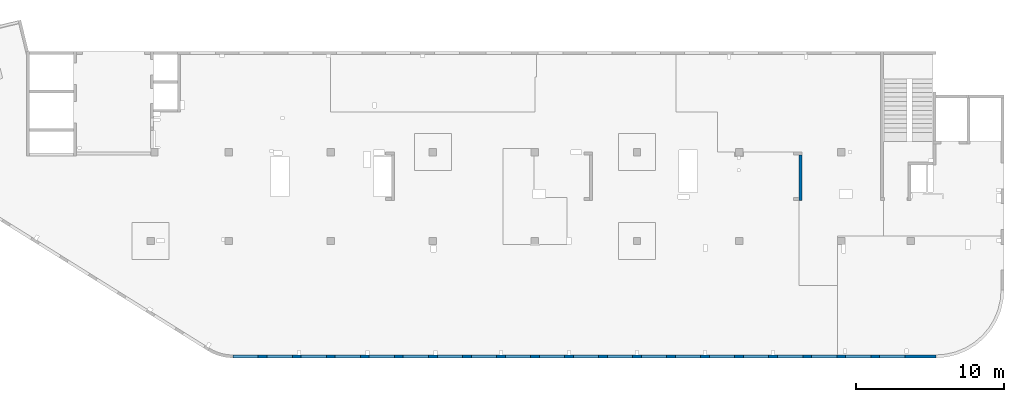
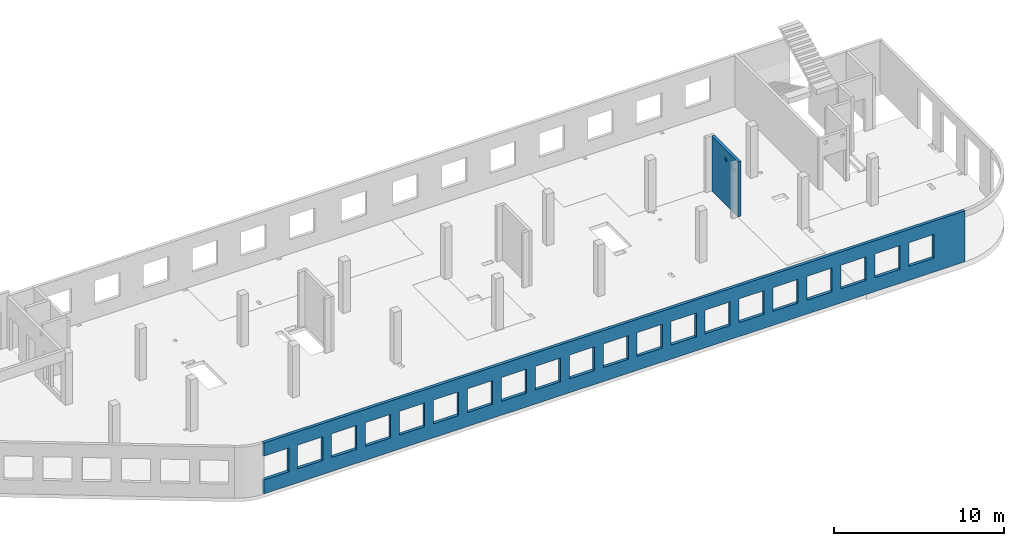
# One storey, part 5 of 6: 2 walls, 22 openings.
"""IFC4 building model written with IfcOpenShell, lengths in millimetres."""

from ifc_helpers import new_model, entity, si_unit, converted_unit, derived_unit, direction, frame, origin, place, context, subcontext, project, spatial, indexed_curve, outline, extrude, polygons, material, type_object, element, save


model = new_model("IFC4")

# Units and contexts
model_context = context("Model", 3, precision=0.01, world=origin(), true_north=direction((6.12303176911189e-17, 1.0)))
plan_context = context("Plan", 3, precision=0.01, world=origin(), true_north=direction((6.12303176911189e-17, 1.0)))
body_context = subcontext(model_context, "Body", "Model", "MODEL_VIEW")
ifc_project = project(units=[si_unit("LENGTHUNIT", "METRE", prefix="MILLI"), si_unit("AREAUNIT", "SQUARE_METRE"), si_unit("VOLUMEUNIT", "CUBIC_METRE"), converted_unit("PLANEANGLEUNIT", "DEGREE", entity("IfcRatioMeasure", 0.0174532925199433), si_unit("PLANEANGLEUNIT", "RADIAN"), dimensions=[0, 0, 0, 0, 0, 0, 0]), si_unit("MASSUNIT", "GRAM", prefix="KILO"), derived_unit("MASSDENSITYUNIT", [(si_unit("MASSUNIT", "GRAM", prefix="KILO"), 1), (si_unit("LENGTHUNIT", "METRE"), -3)]), derived_unit("MOMENTOFINERTIAUNIT", [(si_unit("LENGTHUNIT", "METRE"), 4)]), si_unit("TIMEUNIT", "SECOND"), si_unit("FREQUENCYUNIT", "HERTZ"), si_unit("THERMODYNAMICTEMPERATUREUNIT", "DEGREE_CELSIUS"), derived_unit("THERMALTRANSMITTANCEUNIT", [(si_unit("MASSUNIT", "GRAM", prefix="KILO"), 1), (si_unit("THERMODYNAMICTEMPERATUREUNIT", "KELVIN"), -1), (si_unit("TIMEUNIT", "SECOND"), -3)]), derived_unit("VOLUMETRICFLOWRATEUNIT", [(si_unit("LENGTHUNIT", "METRE"), 3), (si_unit("TIMEUNIT", "SECOND"), -1)]), derived_unit("MASSFLOWRATEUNIT", [(si_unit("MASSUNIT", "GRAM", prefix="KILO"), 1), (si_unit("TIMEUNIT", "SECOND"), -1)]), derived_unit("ROTATIONALFREQUENCYUNIT", [(si_unit("TIMEUNIT", "SECOND"), -1)]), si_unit("ELECTRICCURRENTUNIT", "AMPERE"), si_unit("ELECTRICVOLTAGEUNIT", "VOLT"), si_unit("POWERUNIT", "WATT"), si_unit("FORCEUNIT", "NEWTON", prefix="KILO"), si_unit("ILLUMINANCEUNIT", "LUX"), si_unit("LUMINOUSFLUXUNIT", "LUMEN"), si_unit("LUMINOUSINTENSITYUNIT", "CANDELA"), derived_unit("USERDEFINED", [(si_unit("MASSUNIT", "GRAM", prefix="KILO"), -1), (si_unit("LENGTHUNIT", "METRE"), -2), (si_unit("TIMEUNIT", "SECOND"), 3), (si_unit("LUMINOUSFLUXUNIT", "LUMEN"), 1)]), derived_unit("LINEARVELOCITYUNIT", [(si_unit("LENGTHUNIT", "METRE"), 1), (si_unit("TIMEUNIT", "SECOND"), -1)]), si_unit("PRESSUREUNIT", "PASCAL"), derived_unit("USERDEFINED", [(si_unit("LENGTHUNIT", "METRE"), -2), (si_unit("MASSUNIT", "GRAM", prefix="KILO"), 1), (si_unit("TIMEUNIT", "SECOND"), -2)]), derived_unit("LINEARFORCEUNIT", [(si_unit("MASSUNIT", "GRAM", prefix="KILO"), 1), (si_unit("LENGTHUNIT", "METRE"), 1), (si_unit("TIMEUNIT", "SECOND"), -2), (si_unit("LENGTHUNIT", "METRE"), -1)]), derived_unit("PLANARFORCEUNIT", [(si_unit("MASSUNIT", "GRAM", prefix="KILO"), 1), (si_unit("LENGTHUNIT", "METRE"), 1), (si_unit("TIMEUNIT", "SECOND"), -2), (si_unit("LENGTHUNIT", "METRE"), -2)])], contexts=[model_context, plan_context])

# Site, building, storey
site_placement = place(None, origin())
site = spatial("IfcSite", under=ifc_project, at=site_placement, CompositionType="ELEMENT")
building_placement = place(site_placement, origin())
building = spatial("IfcBuilding", under=site, at=building_placement, CompositionType="ELEMENT")
storey_placement = place(building_placement, frame((0.0, 0.0, 8100.0)))
storey = spatial("IfcBuildingStorey", under=building, at=storey_placement, CompositionType="ELEMENT", Elevation=8100.0)

# Wall, openings
ifc_material = material()
wall_type = type_object("IfcWallType", PredefinedType="STANDARD")
wall_1_placement = place(storey_placement, frame((68970.0002685547, -99.9999557734324, -150.0), z_axis=(0.0, 0.0, 1.0), x_axis=(-1.0, 0.0, 0.0)))
wall_1 = element("IfcWall", 1, at=wall_1_placement, inside=storey, type_object=wall_type, material=ifc_material, PredefinedType="NOTDEFINED", context=body_context, shape_type="Tessellation", body=[
    polygons([(43500.0, -100.000000000321, 2700.0), (45200.0, -100.000000000321, 2700.0), (45200.0, -100.000000000321, 1000.00000000001), (43500.0, -100.000000000321, 1000.00000000001), (41200.0, -100.000000000321, 2700.0), (42900.0, -100.000000000321, 2700.0), (42900.0, -100.000000000321, 1000.00000000001), (41200.0, -100.000000000321, 1000.00000000001), (38900.0, -100.000000000321, 2700.0), (40600.0, -100.000000000321, 2700.0), (40600.0, -100.000000000321, 1000.00000000001), (38900.0, -100.000000000321, 1000.00000000001), (36600.0, -100.000000000321, 2700.0), (38300.0, -100.000000000321, 2700.0), (38300.0, -100.000000000321, 1000.00000000001), (36600.0, -100.000000000321, 1000.00000000001), (34300.0, -100.000000000321, 2700.0), (36000.0, -100.000000000321, 2700.0), (36000.0, -100.000000000321, 1000.00000000001), (34300.0, -100.000000000321, 1000.00000000001), (32000.0, -100.000000000321, 2700.0), (33700.0, -100.000000000321, 2700.0), (33700.0, -100.000000000321, 1000.00000000001), (32000.0, -100.000000000321, 1000.00000000001), (29700.0, -100.000000000321, 2700.0), (31400.0, -100.000000000321, 2700.0), (31400.0, -100.000000000321, 1000.00000000001), (29700.0, -100.000000000321, 1000.00000000001), (27400.0, -100.000000000321, 2700.0), (29100.0, -100.000000000321, 2700.0), (29100.0, -100.000000000321, 1000.00000000001), (27400.0, -100.000000000321, 1000.00000000001), (25100.0, -100.000000000321, 2700.0), (26800.0, -100.000000000321, 2700.0), (26800.0, -100.000000000321, 1000.00000000001), (25100.0, -100.000000000321, 1000.00000000001), (22800.0, -100.000000000321, 2700.0), (24500.0, -100.000000000321, 2700.0), (24500.0, -100.000000000321, 1000.00000000001), (22800.0, -100.000000000321, 1000.00000000001), (20500.0, -100.000000000321, 2700.0), (22200.0, -100.000000000321, 2700.0), (22200.0, -100.000000000321, 1000.00000000001), (20500.0, -100.000000000321, 1000.00000000001), (18200.0, -100.000000000321, 2700.0), (19900.0, -100.000000000321, 2700.0), (19900.0, -100.000000000321, 1000.00000000001), (18200.0, -100.000000000321, 1000.00000000001), (15900.0, -100.000000000321, 2700.0), (17600.0, -100.000000000321, 2700.0), (17600.0, -100.000000000321, 1000.00000000001), (15900.0, -100.000000000321, 1000.00000000001), (13600.0, -100.000000000321, 2700.0), (15300.0, -100.000000000321, 2700.0), (15300.0, -100.000000000321, 1000.00000000001), (13600.0, -100.000000000321, 1000.00000000001), (11300.0, -100.000000000321, 2700.0), (13000.0, -100.000000000321, 2700.0), (13000.0, -100.000000000321, 1000.00000000001), (11300.0, -100.000000000321, 1000.00000000001), (8999.99999999998, -100.000000000321, 2700.0), (10700.0, -100.000000000321, 2700.0), (10700.0, -100.000000000321, 1000.00000000001), (8999.99999999998, -100.000000000321, 1000.00000000001), (6699.99999999998, -100.000000000321, 2700.0), (8399.99999999997, -100.000000000321, 2700.0), (8399.99999999997, -100.000000000321, 1000.00000000001), (6699.99999999998, -100.000000000321, 1000.00000000001), (4399.99999999998, -100.000000000321, 2700.0), (6099.99999999997, -100.000000000321, 2700.0), (6099.99999999997, -100.000000000321, 1000.00000000001), (4399.99999999998, -100.000000000321, 1000.00000000001), (2099.99999999998, -100.000000000321, 2700.0), (3799.99999999998, -100.000000000321, 2700.0), (3799.99999999998, -100.000000000321, 1000.00000000001), (2099.99999999998, -100.000000000321, 1000.00000000001), (8.66293717728731e-12, -100.0, 0.0), (10900.0003342008, -100.0, 0.0), (11100.0003342008, -100.0, 0.0), (15500.0003342008, -100.0, 0.0), (15700.0003342008, -100.0, 0.0), (20100.0, -100.0, 0.0), (20300.0, -100.0, 0.0), (24700.0003342008, -100.0, 0.0), (24900.0003342008, -100.0, 0.0), (38320.0003342008, -100.0, 0.0), (38520.0003342008, -100.0, 0.0), (42930.0, -100.0, 0.0), (43130.0, -100.0, 0.0), (47500.0, -100.0, 0.0), (47500.0, -100.0, 1000.00000000001), (45800.0, -100.000000000321, 1000.00000000001), (45800.0, -100.000000000321, 2700.0), (47500.0, -100.0, 2700.0), (47500.0, -100.0, 3650.0), (8.66293717728731e-12, -100.0, 3650.0), (1.42900165493394e-19, -100.0, 3200.0), (47500.0, 100.0, 0.0), (8.01671852045731e-12, 100.0, 0.0), (-6.46218513929826e-13, 100.0, 3200.0), (8.01671852045731e-12, 100.0, 3650.0), (47500.0, 100.0, 3650.0), (47500.0, 100.0, 2700.0), (45800.0, 100.0, 2700.0), (45800.0, 100.0, 1000.00000000001), (47500.0, 100.0, 1000.00000000001), (45200.0, 100.0, 2700.0), (43500.0, 100.0, 2700.0), (43500.0, 100.0, 1000.00000000001), (45200.0, 100.0, 1000.00000000001), (42900.0, 100.0, 2700.0), (41200.0, 100.0, 2700.0), (41200.0, 100.0, 1000.00000000001), (42900.0, 100.0, 1000.00000000001), (40600.0, 100.0, 2700.0), (38900.0, 100.0, 2700.0), (38900.0, 100.0, 1000.00000000001), (40600.0, 100.0, 1000.00000000001), (38300.0, 100.0, 2700.0), (36600.0, 100.0, 2700.0), (36600.0, 100.0, 1000.00000000001), (38300.0, 100.0, 1000.00000000001), (36000.0, 100.0, 2700.0), (34300.0, 100.0, 2700.0), (34300.0, 100.0, 1000.00000000001), (36000.0, 100.0, 1000.00000000001), (33700.0, 100.0, 2700.0), (32000.0, 100.0, 2700.0), (32000.0, 100.0, 1000.00000000001), (33700.0, 100.0, 1000.00000000001), (31400.0, 100.0, 2700.0), (29700.0, 100.0, 2700.0), (29700.0, 100.0, 1000.00000000001), (31400.0, 100.0, 1000.00000000001), (29100.0, 100.0, 2700.0), (27400.0, 100.0, 2700.0), (27400.0, 100.0, 1000.00000000001), (29100.0, 100.0, 1000.00000000001), (26800.0, 100.0, 2700.0), (25100.0, 100.0, 2700.0), (25100.0, 100.0, 1000.00000000001), (26800.0, 100.0, 1000.00000000001), (24500.0, 100.0, 2700.0), (22800.0, 100.0, 2700.0), (22800.0, 100.0, 1000.00000000001), (24500.0, 100.0, 1000.00000000001), (22200.0, 100.0, 2700.0), (20500.0, 100.0, 2700.0), (20500.0, 100.0, 1000.00000000001), (22200.0, 100.0, 1000.00000000001), (19900.0, 100.0, 2700.0), (18200.0, 100.0, 2700.0), (18200.0, 100.0, 1000.00000000001), (19900.0, 100.0, 1000.00000000001), (17600.0, 100.0, 2700.0), (15900.0, 100.0, 2700.0), (15900.0, 100.0, 1000.00000000001), (17600.0, 100.0, 1000.00000000001), (15300.0, 100.0, 2700.0), (13600.0, 100.0, 2700.0), (13600.0, 100.0, 1000.00000000001), (15300.0, 100.0, 1000.00000000001), (13000.0, 100.0, 2700.0), (11300.0, 100.0, 2700.0), (11300.0, 100.0, 1000.00000000001), (13000.0, 100.0, 1000.00000000001), (10700.0, 100.0, 2700.0), (8999.99999999998, 100.0, 2700.0), (8999.99999999998, 100.0, 1000.00000000001), (10700.0, 100.0, 1000.00000000001), (8399.99999999997, 100.0, 2700.0), (6699.99999999997, 100.0, 2700.0), (6699.99999999997, 100.0, 1000.00000000001), (8399.99999999997, 100.0, 1000.00000000001), (6099.99999999997, 100.0, 2700.0), (4399.99999999998, 100.0, 2700.0), (4399.99999999998, 100.0, 1000.00000000001), (6099.99999999997, 100.0, 1000.00000000001), (3799.99999999998, 100.0, 2700.0), (2099.99999999998, 100.0, 2700.0), (2099.99999999998, 100.0, 1000.00000000001), (3799.99999999998, 100.0, 1000.00000000001)], [[[77, 78, 79, 80, 81, 82, 83, 84, 85, 86, 87, 88, 89, 90, 91, 92, 93, 94, 95, 96, 97], [1, 2, 3, 4], [5, 6, 7, 8], [9, 10, 11, 12], [13, 14, 15, 16], [17, 18, 19, 20], [21, 22, 23, 24], [25, 26, 27, 28], [29, 30, 31, 32], [33, 34, 35, 36], [37, 38, 39, 40], [41, 42, 43, 44], [45, 46, 47, 48], [49, 50, 51, 52], [53, 54, 55, 56], [57, 58, 59, 60], [61, 62, 63, 64], [65, 66, 67, 68], [69, 70, 71, 72], [73, 74, 75, 76]], [[98, 99, 100, 101, 102, 103, 104, 105, 106], [107, 108, 109, 110], [111, 112, 113, 114], [115, 116, 117, 118], [119, 120, 121, 122], [123, 124, 125, 126], [127, 128, 129, 130], [131, 132, 133, 134], [135, 136, 137, 138], [139, 140, 141, 142], [143, 144, 145, 146], [147, 148, 149, 150], [151, 152, 153, 154], [155, 156, 157, 158], [159, 160, 161, 162], [163, 164, 165, 166], [167, 168, 169, 170], [171, 172, 173, 174], [175, 176, 177, 178], [179, 180, 181, 182]], [[90, 89, 88, 87, 86, 85, 84, 83, 82, 81, 80, 79, 78, 77, 99, 98]], [[90, 98, 106, 91]], [[96, 95, 102, 101]], [[77, 97, 96, 101, 100, 99]], [[93, 104, 103, 94]], [[105, 92, 91, 106]], [[104, 93, 92, 105]], [[2, 1, 108, 107]], [[2, 107, 110, 3]], [[3, 110, 109, 4]], [[108, 1, 4, 109]], [[6, 5, 112, 111]], [[6, 111, 114, 7]], [[7, 114, 113, 8]], [[112, 5, 8, 113]], [[10, 9, 116, 115]], [[10, 115, 118, 11]], [[11, 118, 117, 12]], [[116, 9, 12, 117]], [[14, 13, 120, 119]], [[14, 119, 122, 15]], [[15, 122, 121, 16]], [[120, 13, 16, 121]], [[18, 17, 124, 123]], [[18, 123, 126, 19]], [[19, 126, 125, 20]], [[124, 17, 20, 125]], [[22, 21, 128, 127]], [[22, 127, 130, 23]], [[23, 130, 129, 24]], [[128, 21, 24, 129]], [[26, 25, 132, 131]], [[26, 131, 134, 27]], [[27, 134, 133, 28]], [[132, 25, 28, 133]], [[30, 29, 136, 135]], [[30, 135, 138, 31]], [[31, 138, 137, 32]], [[136, 29, 32, 137]], [[34, 33, 140, 139]], [[34, 139, 142, 35]], [[35, 142, 141, 36]], [[140, 33, 36, 141]], [[38, 37, 144, 143]], [[38, 143, 146, 39]], [[39, 146, 145, 40]], [[144, 37, 40, 145]], [[42, 41, 148, 147]], [[42, 147, 150, 43]], [[43, 150, 149, 44]], [[148, 41, 44, 149]], [[46, 45, 152, 151]], [[46, 151, 154, 47]], [[47, 154, 153, 48]], [[152, 45, 48, 153]], [[50, 49, 156, 155]], [[50, 155, 158, 51]], [[51, 158, 157, 52]], [[156, 49, 52, 157]], [[54, 53, 160, 159]], [[54, 159, 162, 55]], [[55, 162, 161, 56]], [[160, 53, 56, 161]], [[58, 57, 164, 163]], [[58, 163, 166, 59]], [[59, 166, 165, 60]], [[164, 57, 60, 165]], [[62, 61, 168, 167]], [[62, 167, 170, 63]], [[63, 170, 169, 64]], [[168, 61, 64, 169]], [[66, 65, 172, 171]], [[66, 171, 174, 67]], [[67, 174, 173, 68]], [[172, 65, 68, 173]], [[70, 69, 176, 175]], [[70, 175, 178, 71]], [[71, 178, 177, 72]], [[176, 69, 72, 177]], [[74, 73, 180, 179]], [[74, 179, 182, 75]], [[75, 182, 181, 76]], [[180, 73, 76, 181]], [[102, 95, 94, 103]]], closed=True),
])
opening_1_placement = place(wall_1_placement, frame((68970.0002685547, -99.9999557734324, 150.0), z_axis=(0.0, 0.0, 1.0), x_axis=(-1.0, 0.0, 0.0)))
element("IfcOpeningElement", 2, at=opening_1_placement, cuts=wall_1, PredefinedType="OPENING", context=body_context, shape_type="SweptSolid", body=[
    extrude(outline(indexed_curve([(-850.000000000002, -849.999999999995), (849.999999999997, -849.999999999995), (849.999999999997, 849.999999999993), (-850.000000000002, 849.999999999993), (-850.000000000002, -849.999999999995)], self_intersect=False)), frame((22320.0002685547, 4.42276800359536e-05, 1700.0), z_axis=(0.0, -1.0, 0.0), x_axis=(-1.0, 0.0, 0.0)), (0.0, 0.0, 1.0), 200.000000000962),
])
opening_2_placement = place(wall_1_placement, frame((68970.0002685547, -99.9999557734324, 150.0), z_axis=(0.0, 0.0, 1.0), x_axis=(-1.0, 0.0, 0.0)))
element("IfcOpeningElement", 3, at=opening_2_placement, cuts=wall_1, PredefinedType="OPENING", context=body_context, shape_type="SweptSolid", body=[
    extrude(outline(indexed_curve([(-849.999999999997, -849.999999999995), (850.000000000006, -849.999999999995), (850.000000000006, 849.999999999993), (-849.999999999997, 849.999999999993), (-849.999999999997, -849.999999999995)], self_intersect=False)), frame((66020.0002685547, 4.4227538823312e-05, 1700.0), z_axis=(0.0, -1.0, 0.0), x_axis=(-1.0, 0.0, 0.0)), (0.0, 0.0, 1.0), 200.000000000962),
])
opening_3_placement = place(wall_1_placement, frame((68970.0002685547, -99.9999557734324, 150.0), z_axis=(0.0, 0.0, 1.0), x_axis=(-1.0, 0.0, 0.0)))
element("IfcOpeningElement", 4, at=opening_3_placement, cuts=wall_1, PredefinedType="OPENING", context=body_context, shape_type="SweptSolid", body=[
    extrude(outline(indexed_curve([(-849.999999999997, -849.999999999995), (850.000000000006, -849.999999999995), (850.000000000006, 849.999999999993), (-849.999999999997, 849.999999999993), (-849.999999999997, -849.999999999995)], self_intersect=False)), frame((63720.0002685547, 4.42275462680235e-05, 1700.0), z_axis=(0.0, -1.0, 0.0), x_axis=(-1.0, 0.0, 0.0)), (0.0, 0.0, 1.0), 200.000000000962),
])
opening_4_placement = place(wall_1_placement, frame((68970.0002685547, -99.9999557734324, 150.0), z_axis=(0.0, 0.0, 1.0), x_axis=(-1.0, 0.0, 0.0)))
element("IfcOpeningElement", 5, at=opening_4_placement, cuts=wall_1, PredefinedType="OPENING", context=body_context, shape_type="SweptSolid", body=[
    extrude(outline(indexed_curve([(-849.999999999997, -849.999999999995), (850.000000000006, -849.999999999995), (850.000000000006, 849.999999999993), (-849.999999999997, 849.999999999993), (-849.999999999997, -849.999999999995)], self_intersect=False)), frame((61420.0002685547, 4.42275536958152e-05, 1700.0), z_axis=(0.0, -1.0, 0.0), x_axis=(-1.0, 0.0, 0.0)), (0.0, 0.0, 1.0), 200.000000000962),
])
opening_5_placement = place(wall_1_placement, frame((68970.0002685547, -99.9999557734324, 150.0), z_axis=(0.0, 0.0, 1.0), x_axis=(-1.0, 0.0, 0.0)))
element("IfcOpeningElement", 6, at=opening_5_placement, cuts=wall_1, PredefinedType="OPENING", context=body_context, shape_type="SweptSolid", body=[
    extrude(outline(indexed_curve([(-849.999999999997, -849.999999999995), (850.000000000006, -849.999999999995), (850.000000000006, 849.999999999993), (-849.999999999997, 849.999999999993), (-849.999999999997, -849.999999999995)], self_intersect=False)), frame((59120.0002685547, 4.4227561123607e-05, 1700.0), z_axis=(0.0, -1.0, 0.0), x_axis=(-1.0, 0.0, 0.0)), (0.0, 0.0, 1.0), 200.000000000962),
])
opening_6_placement = place(wall_1_placement, frame((68970.0002685547, -99.9999557734324, 150.0), z_axis=(0.0, 0.0, 1.0), x_axis=(-1.0, 0.0, 0.0)))
element("IfcOpeningElement", 7, at=opening_6_placement, cuts=wall_1, PredefinedType="OPENING", context=body_context, shape_type="SweptSolid", body=[
    extrude(outline(indexed_curve([(-849.999999999997, -849.999999999995), (850.000000000006, -849.999999999995), (850.000000000006, 849.999999999993), (-849.999999999997, 849.999999999993), (-849.999999999997, -849.999999999995)], self_intersect=False)), frame((56820.0002685547, 4.42275685513987e-05, 1700.0), z_axis=(0.0, -1.0, 0.0), x_axis=(-1.0, 0.0, 0.0)), (0.0, 0.0, 1.0), 200.000000000962),
])
opening_7_placement = place(wall_1_placement, frame((68970.0002685547, -99.9999557734324, 150.0), z_axis=(0.0, 0.0, 1.0), x_axis=(-1.0, 0.0, 0.0)))
element("IfcOpeningElement", 8, at=opening_7_placement, cuts=wall_1, PredefinedType="OPENING", context=body_context, shape_type="SweptSolid", body=[
    extrude(outline(indexed_curve([(-849.999999999997, -849.999999999995), (850.000000000006, -849.999999999995), (850.000000000006, 849.999999999993), (-849.999999999997, 849.999999999993), (-849.999999999997, -849.999999999995)], self_intersect=False)), frame((54520.0002685547, 4.42275759791904e-05, 1700.0), z_axis=(0.0, -1.0, 0.0), x_axis=(-1.0, 0.0, 0.0)), (0.0, 0.0, 1.0), 200.000000000962),
])
opening_8_placement = place(wall_1_placement, frame((68970.0002685547, -99.9999557734324, 150.0), z_axis=(0.0, 0.0, 1.0), x_axis=(-1.0, 0.0, 0.0)))
element("IfcOpeningElement", 9, at=opening_8_placement, cuts=wall_1, PredefinedType="OPENING", context=body_context, shape_type="SweptSolid", body=[
    extrude(outline(indexed_curve([(-849.999999999997, -849.999999999995), (850.000000000006, -849.999999999995), (850.000000000006, 849.999999999993), (-849.999999999997, 849.999999999993), (-849.999999999997, -849.999999999995)], self_intersect=False)), frame((52220.0002685547, 4.42275834239019e-05, 1700.0), z_axis=(0.0, -1.0, 0.0), x_axis=(-1.0, 0.0, 0.0)), (0.0, 0.0, 1.0), 200.000000000962),
])
opening_9_placement = place(wall_1_placement, frame((68970.0002685547, -99.9999557734324, 150.0), z_axis=(0.0, 0.0, 1.0), x_axis=(-1.0, 0.0, 0.0)))
element("IfcOpeningElement", 10, at=opening_9_placement, cuts=wall_1, PredefinedType="OPENING", context=body_context, shape_type="SweptSolid", body=[
    extrude(outline(indexed_curve([(-849.999999999997, -849.999999999995), (850.000000000006, -849.999999999995), (850.000000000006, 849.999999999993), (-849.999999999997, 849.999999999993), (-849.999999999997, -849.999999999995)], self_intersect=False)), frame((49920.0002685547, 4.42275908516936e-05, 1700.0), z_axis=(0.0, -1.0, 0.0), x_axis=(-1.0, 0.0, 0.0)), (0.0, 0.0, 1.0), 200.000000000962),
])
opening_10_placement = place(wall_1_placement, frame((68970.0002685547, -99.9999557734324, 150.0), z_axis=(0.0, 0.0, 1.0), x_axis=(-1.0, 0.0, 0.0)))
element("IfcOpeningElement", 11, at=opening_10_placement, cuts=wall_1, PredefinedType="OPENING", context=body_context, shape_type="SweptSolid", body=[
    extrude(outline(indexed_curve([(-849.999999999997, -849.999999999995), (850.000000000006, -849.999999999995), (850.000000000006, 849.999999999993), (-849.999999999997, 849.999999999993), (-849.999999999997, -849.999999999995)], self_intersect=False)), frame((47620.0002685547, 4.42275982794853e-05, 1700.0), z_axis=(0.0, -1.0, 0.0), x_axis=(-1.0, 0.0, 0.0)), (0.0, 0.0, 1.0), 200.000000000962),
])
opening_11_placement = place(wall_1_placement, frame((68970.0002685547, -99.9999557734324, 150.0), z_axis=(0.0, 0.0, 1.0), x_axis=(-1.0, 0.0, 0.0)))
element("IfcOpeningElement", 12, at=opening_11_placement, cuts=wall_1, PredefinedType="OPENING", context=body_context, shape_type="SweptSolid", body=[
    extrude(outline(indexed_curve([(-849.999999999997, -849.999999999995), (850.000000000006, -849.999999999995), (850.000000000006, 849.999999999993), (-849.999999999997, 849.999999999993), (-849.999999999997, -849.999999999995)], self_intersect=False)), frame((45320.0002685547, 4.4227605707277e-05, 1700.0), z_axis=(0.0, -1.0, 0.0), x_axis=(-1.0, 0.0, 0.0)), (0.0, 0.0, 1.0), 200.000000000962),
])
opening_12_placement = place(wall_1_placement, frame((68970.0002685547, -99.9999557734324, 150.0), z_axis=(0.0, 0.0, 1.0), x_axis=(-1.0, 0.0, 0.0)))
element("IfcOpeningElement", 13, at=opening_12_placement, cuts=wall_1, PredefinedType="OPENING", context=body_context, shape_type="SweptSolid", body=[
    extrude(outline(indexed_curve([(-849.999999999997, -849.999999999995), (850.000000000006, -849.999999999995), (850.000000000006, 849.999999999993), (-849.999999999997, 849.999999999993), (-849.999999999997, -849.999999999995)], self_intersect=False)), frame((43020.0002685547, 4.42276131519886e-05, 1700.0), z_axis=(0.0, -1.0, 0.0), x_axis=(-1.0, 0.0, 0.0)), (0.0, 0.0, 1.0), 200.000000000962),
])
opening_13_placement = place(wall_1_placement, frame((68970.0002685547, -99.9999557734324, 150.0), z_axis=(0.0, 0.0, 1.0), x_axis=(-1.0, 0.0, 0.0)))
element("IfcOpeningElement", 14, at=opening_13_placement, cuts=wall_1, PredefinedType="OPENING", context=body_context, shape_type="SweptSolid", body=[
    extrude(outline(indexed_curve([(-849.999999999997, -849.999999999995), (850.000000000006, -849.999999999995), (850.000000000006, 849.999999999993), (-849.999999999997, 849.999999999993), (-849.999999999997, -849.999999999995)], self_intersect=False)), frame((40720.0002685547, 4.42276205797803e-05, 1700.0), z_axis=(0.0, -1.0, 0.0), x_axis=(-1.0, 0.0, 0.0)), (0.0, 0.0, 1.0), 200.000000000962),
])
opening_14_placement = place(wall_1_placement, frame((68970.0002685547, -99.9999557734324, 150.0), z_axis=(0.0, 0.0, 1.0), x_axis=(-1.0, 0.0, 0.0)))
element("IfcOpeningElement", 15, at=opening_14_placement, cuts=wall_1, PredefinedType="OPENING", context=body_context, shape_type="SweptSolid", body=[
    extrude(outline(indexed_curve([(-849.999999999997, -849.999999999995), (850.000000000002, -849.999999999995), (850.000000000002, 849.999999999993), (-849.999999999997, 849.999999999993), (-849.999999999997, -849.999999999995)], self_intersect=False)), frame((38420.0002685547, 4.4227628007572e-05, 1700.0), z_axis=(0.0, -1.0, 0.0), x_axis=(-1.0, 0.0, 0.0)), (0.0, 0.0, 1.0), 200.000000000962),
])
opening_15_placement = place(wall_1_placement, frame((68970.0002685547, -99.9999557734324, 150.0), z_axis=(0.0, 0.0, 1.0), x_axis=(-1.0, 0.0, 0.0)))
element("IfcOpeningElement", 16, at=opening_15_placement, cuts=wall_1, PredefinedType="OPENING", context=body_context, shape_type="SweptSolid", body=[
    extrude(outline(indexed_curve([(-849.999999999997, -849.999999999995), (850.000000000002, -849.999999999995), (850.000000000002, 849.999999999993), (-849.999999999997, 849.999999999993), (-849.999999999997, -849.999999999995)], self_intersect=False)), frame((36120.0002685547, 4.42276354353637e-05, 1700.0), z_axis=(0.0, -1.0, 0.0), x_axis=(-1.0, 0.0, 0.0)), (0.0, 0.0, 1.0), 200.000000000962),
])
opening_16_placement = place(wall_1_placement, frame((68970.0002685547, -99.9999557734324, 150.0), z_axis=(0.0, 0.0, 1.0), x_axis=(-1.0, 0.0, 0.0)))
element("IfcOpeningElement", 17, at=opening_16_placement, cuts=wall_1, PredefinedType="OPENING", context=body_context, shape_type="SweptSolid", body=[
    extrude(outline(indexed_curve([(-849.999999999997, -849.999999999995), (850.000000000002, -849.999999999995), (850.000000000002, 849.999999999993), (-849.999999999997, 849.999999999993), (-849.999999999997, -849.999999999995)], self_intersect=False)), frame((33820.0002685547, 4.42276428631554e-05, 1700.0), z_axis=(0.0, -1.0, 0.0), x_axis=(-1.0, 0.0, 0.0)), (0.0, 0.0, 1.0), 200.000000000962),
])
opening_17_placement = place(wall_1_placement, frame((68970.0002685547, -99.9999557734324, 150.0), z_axis=(0.0, 0.0, 1.0), x_axis=(-1.0, 0.0, 0.0)))
element("IfcOpeningElement", 18, at=opening_17_placement, cuts=wall_1, PredefinedType="OPENING", context=body_context, shape_type="SweptSolid", body=[
    extrude(outline(indexed_curve([(-849.999999999997, -849.999999999995), (850.000000000002, -849.999999999995), (850.000000000002, 849.999999999993), (-849.999999999997, 849.999999999993), (-849.999999999997, -849.999999999995)], self_intersect=False)), frame((31520.0002685547, 4.42276503078669e-05, 1700.0), z_axis=(0.0, -1.0, 0.0), x_axis=(-1.0, 0.0, 0.0)), (0.0, 0.0, 1.0), 200.000000000962),
])
opening_18_placement = place(wall_1_placement, frame((68970.0002685547, -99.9999557734324, 150.0), z_axis=(0.0, 0.0, 1.0), x_axis=(-1.0, 0.0, 0.0)))
element("IfcOpeningElement", 19, at=opening_18_placement, cuts=wall_1, PredefinedType="OPENING", context=body_context, shape_type="SweptSolid", body=[
    extrude(outline(indexed_curve([(-850.000000000002, -849.999999999995), (849.999999999997, -849.999999999995), (849.999999999997, 849.999999999993), (-850.000000000002, 849.999999999993), (-850.000000000002, -849.999999999995)], self_intersect=False)), frame((29220.0002685547, 4.42276577356586e-05, 1700.0), z_axis=(0.0, -1.0, 0.0), x_axis=(-1.0, 0.0, 0.0)), (0.0, 0.0, 1.0), 200.000000000962),
])
opening_19_placement = place(wall_1_placement, frame((68970.0002685547, -99.9999557734324, 150.0), z_axis=(0.0, 0.0, 1.0), x_axis=(-1.0, 0.0, 0.0)))
element("IfcOpeningElement", 20, at=opening_19_placement, cuts=wall_1, PredefinedType="OPENING", context=body_context, shape_type="SweptSolid", body=[
    extrude(outline(indexed_curve([(-850.000000000002, -849.999999999995), (849.999999999997, -849.999999999995), (849.999999999997, 849.999999999993), (-850.000000000002, 849.999999999993), (-850.000000000002, -849.999999999995)], self_intersect=False)), frame((26920.0002685547, 4.42276651634504e-05, 1700.0), z_axis=(0.0, -1.0, 0.0), x_axis=(-1.0, 0.0, 0.0)), (0.0, 0.0, 1.0), 200.000000000962),
])
opening_20_placement = place(wall_1_placement, frame((68970.0002685547, -99.9999557734324, 150.0), z_axis=(0.0, 0.0, 1.0), x_axis=(-1.0, 0.0, 0.0)))
element("IfcOpeningElement", 21, at=opening_20_placement, cuts=wall_1, PredefinedType="OPENING", context=body_context, shape_type="SweptSolid", body=[
    extrude(outline(indexed_curve([(-850.000000000002, -849.999999999995), (849.999999999997, -849.999999999995), (849.999999999997, 849.999999999993), (-850.000000000002, 849.999999999993), (-850.000000000002, -849.999999999995)], self_intersect=False)), frame((24620.0002685547, 4.42276725912421e-05, 1700.0), z_axis=(0.0, -1.0, 0.0), x_axis=(-1.0, 0.0, 0.0)), (0.0, 0.0, 1.0), 200.000000000962),
])

wall_2_placement = place(storey_placement, frame((59830.0002685547, 13499.9992263555, -150.0), z_axis=(0.0, 0.0, 1.0), x_axis=(0.0, -1.0, 0.0)))
wall_2 = element("IfcWall", 22, at=wall_2_placement, inside=storey, type_object=wall_type, material=ifc_material, PredefinedType="NOTDEFINED", context=body_context, shape_type="Tessellation", body=[
    polygons([(-2.16573425859679e-12, -99.999999999987, 0.0), (2875.00000000001, -99.9999999999967, 0.0), (3075.00000000001, -99.9999999999962, 0.0), (3075.00000000001, -99.9999999999962, 3950.0), (2875.00000000001, -99.9999999999967, 3950.0), (-2.16573425859679e-12, -99.999999999987, 3950.0), (1560.00000000001, -100.000000000009, 3400.0), (1810.00000000001, -100.000000000008, 3400.0), (1810.00000000001, -100.000000000008, 3150.00000000001), (1560.00000000001, -100.000000000009, 3150.00000000001), (2360.00000000001, -100.000000000007, 3330.0), (2710.00000000001, -100.000000000006, 3330.0), (2710.00000000001, -100.000000000006, 2980.00000000001), (2360.00000000001, -100.000000000007, 2980.00000000001), (-2.16573425859679e-12, 100.000000000002, 0.0), (-2.16573425859679e-12, 100.000000000002, 3950.0), (3075.00000000001, 99.999999999993, 3950.0), (3075.00000000001, 99.999999999993, 0.0), (1810.00000000001, 100.000000000319, 3400.0), (1560.00000000001, 100.000000000318, 3400.0), (1560.00000000001, 100.000000000318, 3150.00000000001), (1810.00000000001, 100.000000000319, 3150.00000000001), (2710.00000000001, 100.000000000321, 3330.0), (2360.00000000001, 100.00000000032, 3330.0), (2360.00000000001, 100.00000000032, 2980.00000000001), (2710.00000000001, 100.000000000321, 2980.00000000001)], [[[1, 2, 3, 4, 5, 6], [7, 8, 9, 10], [11, 12, 13, 14]], [[15, 16, 17, 18], [19, 20, 21, 22], [23, 24, 25, 26]], [[3, 2, 1, 15, 18]], [[6, 5, 4, 17, 16]], [[1, 6, 16, 15]], [[4, 3, 18, 17]], [[20, 19, 8, 7]], [[20, 7, 10, 21]], [[21, 10, 9, 22]], [[8, 19, 22, 9]], [[24, 23, 12, 11]], [[24, 11, 14, 25]], [[25, 14, 13, 26]], [[12, 23, 26, 13]]], closed=True),
])
opening_21_placement = place(wall_2_placement, frame((13499.9992263555, -59830.0002685547, 150.0), z_axis=(0.0, 0.0, 1.0), x_axis=(0.0, 1.0, 0.0)))
element("IfcOpeningElement", 23, at=opening_21_placement, cuts=wall_2, PredefinedType="OPENING", context=body_context, shape_type="SweptSolid", body=[
    extrude(outline(indexed_curve([(-174.999999999993, -174.999999999999), (174.999999999993, -174.999999999999), (174.999999999993, 175.000000000001), (-174.999999999993, 175.000000000001), (-174.999999999993, -174.999999999999)], self_intersect=False)), frame((59730.0002685547, 10964.9992263555, 3005.0), z_axis=(1.0, 0.0, 0.0), x_axis=(0.0, 0.0, -1.0)), (0.0, 0.0, 1.0), 200.000000000968),
])
opening_22_placement = place(wall_2_placement, frame((13499.9992263555, -59830.0002685547, 150.0), z_axis=(0.0, 0.0, 1.0), x_axis=(0.0, 1.0, 0.0)))
element("IfcOpeningElement", 24, at=opening_22_placement, cuts=wall_2, PredefinedType="OPENING", context=body_context, shape_type="SweptSolid", body=[
    extrude(outline(indexed_curve([(-124.999999999991, -125.0), (124.999999999993, -125.0), (124.999999999993, 125.0), (-124.999999999991, 125.0), (-124.999999999991, -125.0)], self_intersect=False)), frame((59730.0002685547, 11814.9992263555, 3125.0), z_axis=(1.0, 0.0, 0.0), x_axis=(0.0, 0.0, -1.0)), (0.0, 0.0, 1.0), 200.000000000968),
])

save(model, "model.ifc")
